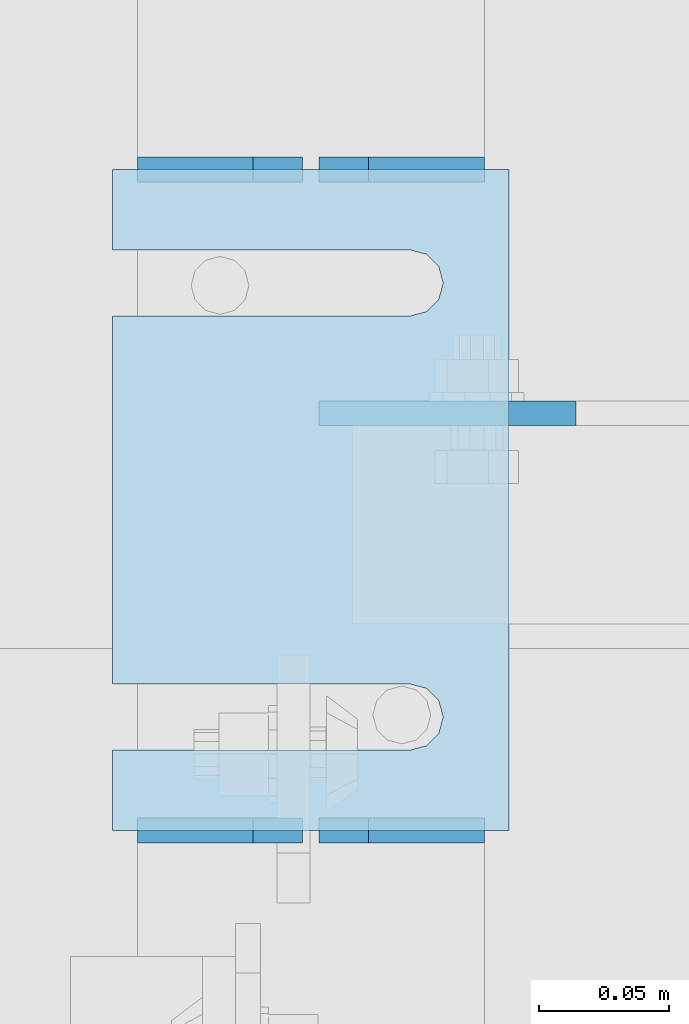
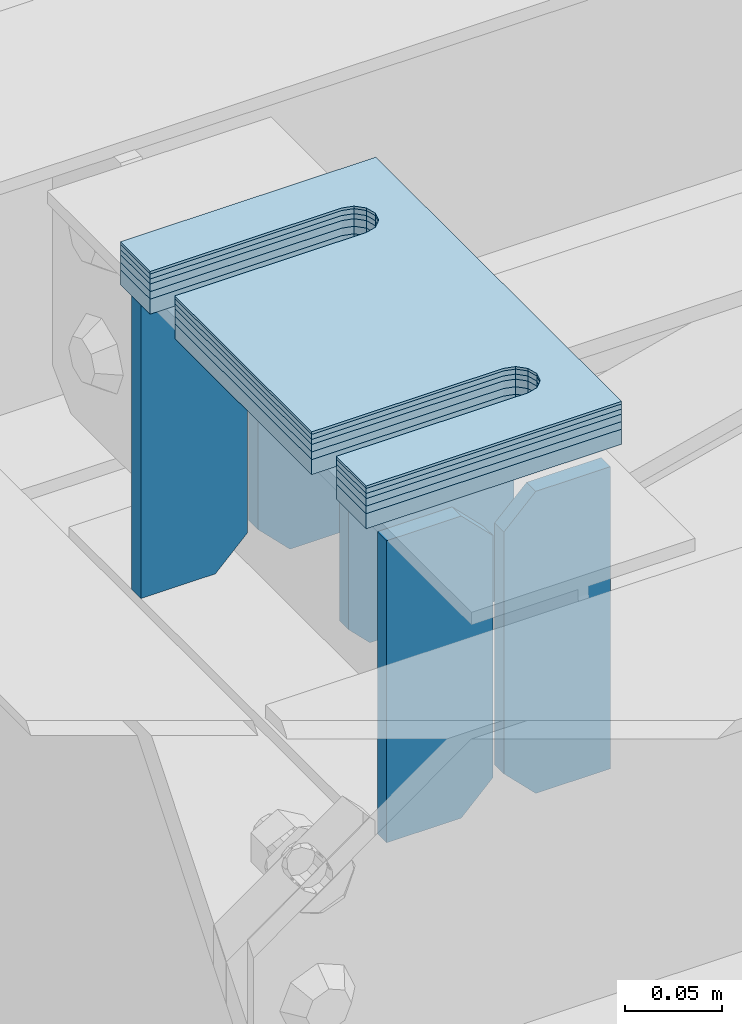
# One storey, part 1631 of 1876: 11 plates, 7 elements without a shape of their own.
"""IFC2X3 building model written with IfcOpenShell, lengths in millimetres."""

from ifc_helpers import new_model, si_unit, frame, origin_with_axes, place, context, subcontext, project, spatial, faceted_brep, material, type_object, element, aggregate, save


model = new_model("IFC2X3")

# Units and contexts
model_context = context("Model", 3, precision=1e-05, world=origin_with_axes())
body_context = subcontext(model_context, "Body", "Model", "MODEL_VIEW")
ifc_project = project(units=[si_unit("LENGTHUNIT", "METRE", prefix="MILLI"), si_unit("AREAUNIT", "SQUARE_METRE"), si_unit("VOLUMEUNIT", "CUBIC_METRE"), si_unit("MASSUNIT", "GRAM", prefix="KILO"), si_unit("TIMEUNIT", "SECOND"), si_unit("PLANEANGLEUNIT", "RADIAN"), si_unit("SOLIDANGLEUNIT", "STERADIAN"), si_unit("THERMODYNAMICTEMPERATUREUNIT", "DEGREE_CELSIUS"), si_unit("LUMINOUSINTENSITYUNIT", "LUMEN")], contexts=[model_context])

# Site, building, storey
site_placement = place(None, origin_with_axes())
site = spatial("IfcSite", under=ifc_project, at=site_placement, CompositionType="ELEMENT")
building_placement = place(site_placement, origin_with_axes())
building = spatial("IfcBuilding", under=site, at=building_placement, Name="Undefined", CompositionType="ELEMENT")
storey_placement = place(building_placement, origin_with_axes())
storey = spatial("IfcBuildingStorey", under=building, at=storey_placement, Name="Undefined", CompositionType="ELEMENT", Elevation=0.0)

# Assembly, plates
assembly_1_placement = place(storey_placement, origin_with_axes())
assembly_1 = element("IfcElementAssembly", 1, at=assembly_1_placement, inside=storey, Name="BEAM", AssemblyPlace="NOTDEFINED", PredefinedType="RIGID_FRAME")
ifc_material = material(Name="STEEL/A36")
plate_type_1 = type_object("IfcPlateType", PredefinedType="NOTDEFINED")
plate_1_placement = place(assembly_1_placement, frame((3188.08048423619, 5588.01551299106, 17784.7625), z_axis=(0.0, 0.0, 1.0), x_axis=(-1.0, 0.0, 0.0)))
plate_1 = element("IfcPlate", 2, at=plate_1_placement, type_object=plate_type_1, material=ifc_material, Name="PLATE", context=body_context, shape_type="Brep", body=[
    faceted_brep([(0.0, -4.76249999999982, 0.0), (0.0, -4.76249999999982, 190.5), (0.0, 4.76249999999982, 190.5), (0.0, 4.76249999999982, 0.0), (44.4500007629395, -4.76249999999982, 190.5), (44.4500007629395, 4.76249999999982, 190.5), (63.5, -4.76249999999982, 171.450000762939), (63.5, 4.76249999999982, 171.450000762939), (63.5, -4.76249999999982, 19.0499992370605), (63.5, 4.76249999999982, 19.0499992370605), (44.4500007629395, -4.76249999999982, 0.0), (44.4500007629395, 4.76249999999982, 0.0)], [[[0, 1, 2, 3]], [[1, 4, 5, 2]], [[4, 6, 7, 5]], [[6, 8, 9, 7]], [[8, 10, 11, 9]], [[10, 0, 3, 11]], [[5, 7, 9, 11, 3, 2]], [[10, 8, 6, 4, 1, 0]]]),
])
plate_2_placement = place(assembly_1_placement, frame((3118.23048423619, 5588.01551299106, 17784.7625), z_axis=(0.0, 0.0, 1.0), x_axis=(-1.0, 0.0, 0.0)))
plate_2 = element("IfcPlate", 3, at=plate_2_placement, type_object=plate_type_1, material=ifc_material, Name="PLATE", context=body_context, shape_type="Brep", body=[
    faceted_brep([(0.0, -4.76249999999982, 19.0499992370605), (0.0, -4.76249999999982, 171.450000762939), (0.0, 4.76249999999982, 171.450000762939), (0.0, 4.76249999999982, 19.0499992370605), (19.0499992370605, -4.76249999999982, 190.5), (19.0499992370605, 4.76249999999982, 190.5), (63.5, -4.76249999999982, 190.5), (63.5, 4.76249999999982, 190.5), (63.5, -4.76249999999982, 0.0), (63.5, 4.76249999999982, 0.0), (19.0499992370605, -4.76249999999982, 0.0), (19.0499992370605, 4.76249999999982, 0.0)], [[[0, 1, 2, 3]], [[1, 4, 5, 2]], [[4, 6, 7, 5]], [[6, 8, 9, 7]], [[8, 10, 11, 9]], [[10, 0, 3, 11]], [[5, 7, 9, 11, 3, 2]], [[10, 8, 6, 4, 1, 0]]]),
])
plate_3_placement = place(assembly_1_placement, frame((3188.08048423619, 5842.01505094658, 17784.7625), z_axis=(0.0, 0.0, 1.0), x_axis=(-1.0, 0.0, 0.0)))
plate_3 = element("IfcPlate", 4, at=plate_3_placement, type_object=plate_type_1, material=ifc_material, Name="PLATE", context=body_context, shape_type="Brep", body=[
    faceted_brep([(0.0, -4.76249999999982, 0.0), (0.0, -4.76249999999982, 190.5), (0.0, 4.76249999999982, 190.5), (0.0, 4.76249999999982, 0.0), (44.4500007629395, -4.76249999999982, 190.5), (44.4500007629395, 4.76249999999982, 190.5), (63.5, -4.76249999999982, 171.450000762939), (63.5, 4.76249999999982, 171.450000762939), (63.5, -4.76249999999982, 19.0499992370605), (63.5, 4.76249999999982, 19.0499992370605), (44.4500007629395, -4.76249999999982, 0.0), (44.4500007629395, 4.76249999999982, 0.0)], [[[0, 1, 2, 3]], [[1, 4, 5, 2]], [[4, 6, 7, 5]], [[6, 8, 9, 7]], [[8, 10, 11, 9]], [[10, 0, 3, 11]], [[5, 7, 9, 11, 3, 2]], [[10, 8, 6, 4, 1, 0]]]),
])
plate_4_placement = place(assembly_1_placement, frame((3118.23048423619, 5842.01505094658, 17784.7625), z_axis=(0.0, 0.0, 1.0), x_axis=(-1.0, 0.0, 0.0)))
plate_4 = element("IfcPlate", 5, at=plate_4_placement, type_object=plate_type_1, material=ifc_material, Name="PLATE", context=body_context, shape_type="Brep", body=[
    faceted_brep([(0.0, -4.76249999999982, 19.0499992370605), (0.0, -4.76249999999982, 171.450000762939), (0.0, 4.76249999999982, 171.450000762939), (0.0, 4.76249999999982, 19.0499992370605), (19.0499992370605, -4.76249999999982, 190.5), (19.0499992370605, 4.76249999999982, 190.5), (63.5, -4.76249999999982, 190.5), (63.5, 4.76249999999982, 190.5), (63.5, -4.76249999999982, 0.0), (63.5, 4.76249999999982, 0.0), (19.0499992370605, -4.76249999999982, 0.0), (19.0499992370605, 4.76249999999982, 0.0)], [[[0, 1, 2, 3]], [[1, 4, 5, 2]], [[4, 6, 7, 5]], [[6, 8, 9, 7]], [[8, 10, 11, 9]], [[10, 0, 3, 11]], [[5, 7, 9, 11, 3, 2]], [[10, 8, 6, 4, 1, 0]]]),
])
plate_type_2 = type_object("IfcPlateType", PredefinedType="NOTDEFINED")
plate_5_placement = place(assembly_1_placement, frame((3223.25213082928, 5748.35276155761, 17784.7625), z_axis=(-1.0, 0.0, 0.0), x_axis=(0.0, 0.0, 1.0)))
plate_5 = element("IfcPlate", 6, at=plate_5_placement, type_object=plate_type_2, material=ifc_material, Name="PLATE", context=body_context, shape_type="Brep", body=[
    faceted_brep([(0.0, -4.76249999999982, 0.0), (0.0, -4.76249999999163, 85.9716234207167), (0.0, 4.762500000008, 85.9716234207158), (0.0, 4.76249999999982, 0.0), (12.6999998092651, -4.76249999999072, 98.6716210911795), (12.6999998092651, 4.76250000000891, 98.6716210911786), (90.6052093505859, -4.76249999999072, 98.6716079711928), (90.6052093505859, 4.76250000000982, 98.6716079711914), (90.6052093505859, -4.76249999999891, 1.81898940354586e-12), (90.6052093505859, 4.76250000000073, 4.54747350886464e-13)], [[[0, 1, 2, 3]], [[1, 4, 5, 2]], [[4, 6, 7, 5]], [[6, 8, 9, 7]], [[8, 0, 3, 9]], [[5, 7, 9, 3, 2]], [[8, 6, 4, 1, 0]]]),
])
aggregate(assembly_1, [plate_1, plate_2, plate_3, plate_4, plate_5])

# Assembly, plate
assembly_2_placement = place(storey_placement, origin_with_axes())
assembly_2 = element("IfcElementAssembly", 7, at=assembly_2_placement, inside=storey, Name="SHIM PLATE", AssemblyPlace="NOTDEFINED", PredefinedType="RIGID_FRAME")
plate_type_3 = type_object("IfcPlateType", PredefinedType="NOTDEFINED")
plate_6_placement = place(assembly_2_placement, frame((3197.61613617069, 5588.01549354666, 18009.3925), z_axis=(-1.0, 0.0, 0.0), x_axis=(0.0, 1.0, 0.0)))
plate_6 = element("IfcPlate", 8, at=plate_6_placement, type_object=plate_type_3, material=ifc_material, Name="SHIM PLATE", context=body_context, shape_type="Brep", body=[
    faceted_brep([(30.8791924037423, -0.793499999999767, 152.398895263674), (30.8814140421409, -0.793499999999767, 38.0994505407325), (30.8814140421409, 0.793499999999767, 38.0994505407325), (30.8791924037423, 0.793499999999767, 152.398895263674), (32.5828868936751, -0.793499999999767, 31.7494480341243), (32.5828868936751, 0.793499999999767, 31.7494480341243), (37.2314075583954, -0.793499999999767, 27.1009216732054), (37.2314075583954, 0.793499999999767, 27.1009216732054), (43.5814079800521, -0.793499999999767, 25.3994410405157), (43.5814079800521, 0.793499999999767, 25.3994410405157), (49.9314097200559, -0.793499999999767, 27.1009167530574), (49.9314097200559, 0.793499999999767, 27.1009167530574), (54.5799339865616, -0.793499999999767, 31.7494395121785), (54.5799339865616, 0.793499999999767, 31.7494395121785), (56.2814117582284, -0.793499999999767, 38.0994407004391), (56.2814117582284, 0.793499999999767, 38.0994407004391), (56.2791901197206, -0.793499999999767, 152.398894414155), (56.2791901197206, 0.793499999999767, 152.398895263676), (9.09494701772928e-13, -0.793499999999767, 0.0), (1.98268335225293e-05, -0.793499999999767, 152.398895263672), (1.98268335225293e-05, 0.793499999999767, 152.398895263672), (9.09494701772928e-13, 0.793499999999767, 0.0), (253.999542236328, -0.793499999999767, 6.16182660451159e-11), (253.999542236328, 0.793499999999767, 6.16182660451159e-11), (253.999557495107, -0.793499999999767, 152.398895263688), (253.999557495107, 0.793499999999767, 152.398895263688), (223.116882380463, 0.793499999999767, 152.398895263686), (223.116882380463, -0.793499999999767, 152.398895415181), (223.119104018971, 0.793499999999767, 38.0994417014649), (223.119104018971, -0.793499999999767, 38.0994417014649), (221.417626247304, 0.793499999999767, 31.7494405132047), (221.417626247304, -0.793499999999767, 31.7494405132047), (216.769101980798, 0.793499999999767, 27.1009177540836), (216.769101980798, -0.793499999999767, 27.1009177540836), (210.419100240794, 0.793499999999767, 25.399442041542), (210.419100240794, -0.793499999999767, 25.399442041542), (204.069099819138, 0.793499999999767, 27.1009226742317), (204.069099819138, -0.793499999999767, 27.1009226742317), (199.420579154417, 0.793499999999767, 31.7494490351505), (199.420579154417, -0.793499999999767, 31.7494490351505), (197.719106302883, 0.793499999999767, 38.0994515417583), (197.719106302883, -0.793499999999767, 38.0994515417583), (197.716884664484, -0.793499999999767, 152.398895263684), (197.716884664484, 0.793499999999767, 152.398895263684)], [[[0, 1, 2, 3]], [[4, 5, 2, 1]], [[6, 7, 5, 4]], [[8, 9, 7, 6]], [[10, 11, 9, 8]], [[12, 13, 11, 10]], [[14, 15, 13, 12]], [[16, 17, 15, 14]], [[18, 19, 20, 21]], [[22, 18, 21, 23]], [[24, 22, 23, 25]], [[24, 25, 26, 27]], [[27, 26, 28, 29]], [[29, 28, 30, 31]], [[31, 30, 32, 33]], [[33, 32, 34, 35]], [[35, 34, 36, 37]], [[37, 36, 38, 39]], [[39, 38, 40, 41]], [[42, 41, 40, 43]], [[12, 10, 8, 6, 4, 1, 0, 19, 18, 22, 24, 27, 29, 31, 33, 35, 37, 39, 41, 42, 16, 14]], [[20, 19, 0, 3]], [[43, 40, 38, 36, 34, 32, 30, 28, 26, 25, 23, 21, 20, 3, 2, 5, 7, 9, 11, 13, 15, 17]], [[42, 43, 17, 16]]]),
])
aggregate(assembly_2, [plate_6])

assembly_3_placement = place(storey_placement, origin_with_axes())
assembly_3 = element("IfcElementAssembly", 9, at=assembly_3_placement, inside=storey, Name="SHIM PLATE", AssemblyPlace="NOTDEFINED", PredefinedType="RIGID_FRAME")
plate_type_4 = type_object("IfcPlateType", PredefinedType="NOTDEFINED")
plate_7_placement = place(assembly_3_placement, frame((3197.61613617092, 5588.01549354666, 18007.0115), z_axis=(-1.0, 0.0, 0.0), x_axis=(0.0, 1.0, 0.0)))
plate_7 = element("IfcPlate", 10, at=plate_7_placement, type_object=plate_type_4, material=ifc_material, Name="SHIM PLATE", context=body_context, shape_type="Brep", body=[
    faceted_brep([(30.8791924037423, -1.58750000000146, 152.398895263674), (30.8814140421409, -1.58750000000146, 38.0994505407325), (30.8814140421409, 1.58750000000146, 38.0994505407325), (30.8791924037423, 1.58750000000146, 152.398895263674), (32.5828868936751, -1.58750000000146, 31.7494480341243), (32.5828868936751, 1.58750000000146, 31.7494480341243), (37.2314075583954, -1.58750000000146, 27.1009216732054), (37.2314075583954, 1.58750000000146, 27.1009216732054), (43.5814079800521, -1.58750000000146, 25.3994410405157), (43.5814079800521, 1.58750000000146, 25.3994410405157), (49.9314097200559, -1.58750000000146, 27.1009167530574), (49.9314097200559, 1.58750000000146, 27.1009167530574), (54.5799339865616, -1.58750000000146, 31.7494395121785), (54.5799339865616, 1.58750000000146, 31.7494395121785), (56.2814117582284, -1.58750000000146, 38.0994407004391), (56.2814117582284, 1.58750000000146, 38.0994407004391), (56.2791901197206, -1.58750000000146, 152.398894414155), (56.2791901197206, 1.58750000000146, 152.398895263676), (9.09494701772928e-13, -1.58750000000146, 4.54747350886464e-13), (1.98264133359771e-05, -1.58750000000146, 152.398895263672), (1.98264133359771e-05, 1.58750000000146, 152.398895263672), (9.09494701772928e-13, 1.58750000000146, 4.54747350886464e-13), (253.999542236328, -1.58750000000146, 6.16182660451159e-11), (253.999542236328, 1.58750000000146, 6.16182660451159e-11), (253.999557495107, -1.58750000000146, 152.398895263688), (253.999557495107, 1.58750000000146, 152.398895263688), (223.116882380463, 1.58750000000146, 152.398895263686), (223.116882380463, -1.58750000000146, 152.398895415181), (223.119104018971, 1.58750000000146, 38.0994417014649), (223.119104018971, -1.58750000000146, 38.0994417014649), (221.417626247304, 1.58750000000146, 31.7494405132047), (221.417626247304, -1.58750000000146, 31.7494405132047), (216.769101980798, 1.58750000000146, 27.1009177540836), (216.769101980798, -1.58750000000146, 27.1009177540836), (210.419100240794, 1.58750000000146, 25.399442041542), (210.419100240794, -1.58750000000146, 25.399442041542), (204.069099819138, 1.58750000000146, 27.1009226742317), (204.069099819138, -1.58750000000146, 27.1009226742317), (199.420579154417, 1.58750000000146, 31.7494490351505), (199.420579154417, -1.58750000000146, 31.7494490351505), (197.719106302883, 1.58750000000146, 38.0994515417583), (197.719106302883, -1.58750000000146, 38.0994515417583), (197.716884664484, -1.58750000000146, 152.398895263684), (197.716884664484, 1.58750000000146, 152.398895263684)], [[[0, 1, 2, 3]], [[4, 5, 2, 1]], [[6, 7, 5, 4]], [[8, 9, 7, 6]], [[10, 11, 9, 8]], [[12, 13, 11, 10]], [[14, 15, 13, 12]], [[16, 17, 15, 14]], [[18, 19, 20, 21]], [[22, 18, 21, 23]], [[24, 22, 23, 25]], [[24, 25, 26, 27]], [[27, 26, 28, 29]], [[29, 28, 30, 31]], [[31, 30, 32, 33]], [[33, 32, 34, 35]], [[35, 34, 36, 37]], [[37, 36, 38, 39]], [[39, 38, 40, 41]], [[42, 41, 40, 43]], [[12, 10, 8, 6, 4, 1, 0, 19, 18, 22, 24, 27, 29, 31, 33, 35, 37, 39, 41, 42, 16, 14]], [[20, 19, 0, 3]], [[43, 40, 38, 36, 34, 32, 30, 28, 26, 25, 23, 21, 20, 3, 2, 5, 7, 9, 11, 13, 15, 17]], [[42, 43, 17, 16]]]),
])
aggregate(assembly_3, [plate_7])

assembly_4_placement = place(storey_placement, origin_with_axes())
assembly_4 = element("IfcElementAssembly", 11, at=assembly_4_placement, inside=storey, Name="SHIM PLATE", AssemblyPlace="NOTDEFINED", PredefinedType="RIGID_FRAME")
plate_8_placement = place(assembly_4_placement, frame((3197.61613617115, 5588.01549354666, 18003.8365), z_axis=(-1.0, 0.0, 0.0), x_axis=(0.0, 1.0, 0.0)))
plate_8 = element("IfcPlate", 12, at=plate_8_placement, type_object=plate_type_4, material=ifc_material, Name="SHIM PLATE", context=body_context, shape_type="Brep", body=[
    faceted_brep([(30.8791924037423, -1.58750000000146, 152.398895263674), (30.8814140421409, -1.58750000000146, 38.0994505407325), (30.8814140421409, 1.58750000000146, 38.0994505407325), (30.8791924037423, 1.58750000000146, 152.398895263674), (32.5828868936751, -1.58750000000146, 31.7494480341243), (32.5828868936751, 1.58750000000146, 31.7494480341243), (37.2314075583954, -1.58750000000146, 27.1009216732054), (37.2314075583954, 1.58750000000146, 27.1009216732054), (43.5814079800521, -1.58750000000146, 25.3994410405157), (43.5814079800521, 1.58750000000146, 25.3994410405157), (49.9314097200559, -1.58750000000146, 27.1009167530574), (49.9314097200559, 1.58750000000146, 27.1009167530574), (54.5799339865616, -1.58750000000146, 31.7494395121785), (54.5799339865616, 1.58750000000146, 31.7494395121785), (56.2814117582284, -1.58750000000146, 38.0994407004391), (56.2814117582284, 1.58750000000146, 38.0994407004391), (56.2791901197206, -1.58750000000146, 152.398894414155), (56.2791901197206, 1.58750000000146, 152.398895263676), (9.09494701772928e-13, -1.58750000000146, 4.54747350886464e-13), (1.98264133359771e-05, -1.58750000000146, 152.398895263672), (1.98264133359771e-05, 1.58750000000146, 152.398895263672), (9.09494701772928e-13, 1.58750000000146, 4.54747350886464e-13), (253.999542236328, -1.58750000000146, 6.16182660451159e-11), (253.999542236328, 1.58750000000146, 6.16182660451159e-11), (253.999557495107, -1.58750000000146, 152.398895263688), (253.999557495107, 1.58750000000146, 152.398895263688), (223.116882380463, 1.58750000000146, 152.398895263686), (223.116882380463, -1.58750000000146, 152.398895415181), (223.119104018971, 1.58750000000146, 38.0994417014649), (223.119104018971, -1.58750000000146, 38.0994417014649), (221.417626247304, 1.58750000000146, 31.7494405132047), (221.417626247304, -1.58750000000146, 31.7494405132047), (216.769101980798, 1.58750000000146, 27.1009177540836), (216.769101980798, -1.58750000000146, 27.1009177540836), (210.419100240794, 1.58750000000146, 25.399442041542), (210.419100240794, -1.58750000000146, 25.399442041542), (204.069099819138, 1.58750000000146, 27.1009226742317), (204.069099819138, -1.58750000000146, 27.1009226742317), (199.420579154417, 1.58750000000146, 31.7494490351505), (199.420579154417, -1.58750000000146, 31.7494490351505), (197.719106302883, 1.58750000000146, 38.0994515417583), (197.719106302883, -1.58750000000146, 38.0994515417583), (197.716884664484, -1.58750000000146, 152.398895263684), (197.716884664484, 1.58750000000146, 152.398895263684)], [[[0, 1, 2, 3]], [[4, 5, 2, 1]], [[6, 7, 5, 4]], [[8, 9, 7, 6]], [[10, 11, 9, 8]], [[12, 13, 11, 10]], [[14, 15, 13, 12]], [[16, 17, 15, 14]], [[18, 19, 20, 21]], [[22, 18, 21, 23]], [[24, 22, 23, 25]], [[24, 25, 26, 27]], [[27, 26, 28, 29]], [[29, 28, 30, 31]], [[31, 30, 32, 33]], [[33, 32, 34, 35]], [[35, 34, 36, 37]], [[37, 36, 38, 39]], [[39, 38, 40, 41]], [[42, 41, 40, 43]], [[12, 10, 8, 6, 4, 1, 0, 19, 18, 22, 24, 27, 29, 31, 33, 35, 37, 39, 41, 42, 16, 14]], [[20, 19, 0, 3]], [[43, 40, 38, 36, 34, 32, 30, 28, 26, 25, 23, 21, 20, 3, 2, 5, 7, 9, 11, 13, 15, 17]], [[42, 43, 17, 16]]]),
])
aggregate(assembly_4, [plate_8])

assembly_5_placement = place(storey_placement, origin_with_axes())
assembly_5 = element("IfcElementAssembly", 13, at=assembly_5_placement, inside=storey, Name="SHIM PLATE", AssemblyPlace="NOTDEFINED", PredefinedType="RIGID_FRAME")
plate_type_5 = type_object("IfcPlateType", PredefinedType="NOTDEFINED")
plate_9_placement = place(assembly_5_placement, frame((3197.61613617138, 5588.01549354666, 17999.868), z_axis=(-1.0, 0.0, 0.0), x_axis=(0.0, 1.0, 0.0)))
plate_9 = element("IfcPlate", 14, at=plate_9_placement, type_object=plate_type_5, material=ifc_material, Name="SHIM PLATE", context=body_context, shape_type="Brep", body=[
    faceted_brep([(30.8791924037423, -2.38100000000122, 152.398895263674), (30.8814140421409, -2.38100000000122, 38.0994505407325), (30.8814140421409, 2.38100000000122, 38.0994505407325), (30.8791924037423, 2.38100000000122, 152.398895263674), (32.5828868936751, -2.38100000000122, 31.7494480341243), (32.5828868936751, 2.38100000000122, 31.7494480341243), (37.2314075583954, -2.38100000000122, 27.1009216732054), (37.2314075583954, 2.38100000000122, 27.1009216732054), (43.5814079800521, -2.38100000000122, 25.3994410405157), (43.5814079800521, 2.38100000000122, 25.3994410405157), (49.9314097200559, -2.38100000000122, 27.1009167530574), (49.9314097200559, 2.38100000000122, 27.1009167530574), (54.5799339865616, -2.38100000000122, 31.7494395121785), (54.5799339865616, 2.38100000000122, 31.7494395121785), (56.2814117582284, -2.38100000000122, 38.0994407004391), (56.2814117582284, 2.38100000000122, 38.0994407004391), (56.2791901197206, -2.38100000000122, 152.398894414155), (56.2791901197206, 2.38100000000122, 152.398895263676), (0.0, -2.38100000000122, 4.54747350886464e-13), (1.98259931494249e-05, -2.38100000000122, 152.398895263672), (1.98259931494249e-05, 2.38100000000122, 152.398895263672), (0.0, 2.38100000000122, 4.54747350886464e-13), (253.999542236328, -2.38100000000122, 6.16182660451159e-11), (253.999542236328, 2.38100000000122, 6.16182660451159e-11), (253.999557495107, -2.38100000000122, 152.398895263688), (253.999557495107, 2.38100000000122, 152.398895263688), (223.116882380463, 2.38100000000122, 152.398895263686), (223.116882380463, -2.38100000000122, 152.398895415181), (223.119104018971, 2.38100000000122, 38.0994417014649), (223.119104018971, -2.38100000000122, 38.0994417014649), (221.417626247304, 2.38100000000122, 31.7494405132047), (221.417626247304, -2.38100000000122, 31.7494405132047), (216.769101980798, 2.38100000000122, 27.1009177540836), (216.769101980798, -2.38100000000122, 27.1009177540836), (210.419100240794, 2.38100000000122, 25.399442041542), (210.419100240794, -2.38100000000122, 25.399442041542), (204.069099819138, 2.38100000000122, 27.1009226742317), (204.069099819138, -2.38100000000122, 27.1009226742317), (199.420579154417, 2.38100000000122, 31.7494490351505), (199.420579154417, -2.38100000000122, 31.7494490351505), (197.719106302883, 2.38100000000122, 38.0994515417583), (197.719106302883, -2.38100000000122, 38.0994515417583), (197.716884664484, -2.38100000000122, 152.398895263684), (197.716884664484, 2.38100000000122, 152.398895263684)], [[[0, 1, 2, 3]], [[4, 5, 2, 1]], [[6, 7, 5, 4]], [[8, 9, 7, 6]], [[10, 11, 9, 8]], [[12, 13, 11, 10]], [[14, 15, 13, 12]], [[16, 17, 15, 14]], [[18, 19, 20, 21]], [[22, 18, 21, 23]], [[24, 22, 23, 25]], [[24, 25, 26, 27]], [[27, 26, 28, 29]], [[29, 28, 30, 31]], [[31, 30, 32, 33]], [[33, 32, 34, 35]], [[35, 34, 36, 37]], [[37, 36, 38, 39]], [[39, 38, 40, 41]], [[42, 41, 40, 43]], [[12, 10, 8, 6, 4, 1, 0, 19, 18, 22, 24, 27, 29, 31, 33, 35, 37, 39, 41, 42, 16, 14]], [[20, 19, 0, 3]], [[43, 40, 38, 36, 34, 32, 30, 28, 26, 25, 23, 21, 20, 3, 2, 5, 7, 9, 11, 13, 15, 17]], [[42, 43, 17, 16]]]),
])
aggregate(assembly_5, [plate_9])

assembly_6_placement = place(storey_placement, origin_with_axes())
assembly_6 = element("IfcElementAssembly", 15, at=assembly_6_placement, inside=storey, Name="SHIM PLATE", AssemblyPlace="NOTDEFINED", PredefinedType="RIGID_FRAME")
plate_10_placement = place(assembly_6_placement, frame((3197.61613617161, 5588.01549354666, 17995.106), z_axis=(-1.0, 0.0, 0.0), x_axis=(0.0, 1.0, 0.0)))
plate_10 = element("IfcPlate", 16, at=plate_10_placement, type_object=plate_type_5, material=ifc_material, Name="SHIM PLATE", context=body_context, shape_type="Brep", body=[
    faceted_brep([(30.8791924037423, -2.38100000000122, 152.398895263674), (30.8814140421409, -2.38100000000122, 38.0994505407325), (30.8814140421409, 2.38100000000122, 38.0994505407325), (30.8791924037423, 2.38100000000122, 152.398895263674), (32.5828868936751, -2.38100000000122, 31.7494480341243), (32.5828868936751, 2.38100000000122, 31.7494480341243), (37.2314075583954, -2.38100000000122, 27.1009216732054), (37.2314075583954, 2.38100000000122, 27.1009216732054), (43.5814079800521, -2.38100000000122, 25.3994410405157), (43.5814079800521, 2.38100000000122, 25.3994410405157), (49.9314097200559, -2.38100000000122, 27.1009167530574), (49.9314097200559, 2.38100000000122, 27.1009167530574), (54.5799339865616, -2.38100000000122, 31.7494395121785), (54.5799339865616, 2.38100000000122, 31.7494395121785), (56.2814117582284, -2.38100000000122, 38.0994407004391), (56.2814117582284, 2.38100000000122, 38.0994407004391), (56.2791901197206, -2.38100000000122, 152.398894414155), (56.2791901197206, 2.38100000000122, 152.398895263676), (0.0, -2.38100000000122, 4.54747350886464e-13), (1.98259931494249e-05, -2.38100000000122, 152.398895263672), (1.98259931494249e-05, 2.38100000000122, 152.398895263672), (0.0, 2.38100000000122, 4.54747350886464e-13), (253.999542236328, -2.38100000000122, 6.16182660451159e-11), (253.999542236328, 2.38100000000122, 6.16182660451159e-11), (253.999557495107, -2.38100000000122, 152.398895263688), (253.999557495107, 2.38100000000122, 152.398895263688), (223.116882380463, 2.38100000000122, 152.398895263686), (223.116882380463, -2.38100000000122, 152.398895415181), (223.119104018971, 2.38100000000122, 38.0994417014649), (223.119104018971, -2.38100000000122, 38.0994417014649), (221.417626247304, 2.38100000000122, 31.7494405132047), (221.417626247304, -2.38100000000122, 31.7494405132047), (216.769101980798, 2.38100000000122, 27.1009177540836), (216.769101980798, -2.38100000000122, 27.1009177540836), (210.419100240794, 2.38100000000122, 25.399442041542), (210.419100240794, -2.38100000000122, 25.399442041542), (204.069099819138, 2.38100000000122, 27.1009226742317), (204.069099819138, -2.38100000000122, 27.1009226742317), (199.420579154417, 2.38100000000122, 31.7494490351505), (199.420579154417, -2.38100000000122, 31.7494490351505), (197.719106302883, 2.38100000000122, 38.0994515417583), (197.719106302883, -2.38100000000122, 38.0994515417583), (197.716884664484, -2.38100000000122, 152.398895263684), (197.716884664484, 2.38100000000122, 152.398895263684)], [[[0, 1, 2, 3]], [[4, 5, 2, 1]], [[6, 7, 5, 4]], [[8, 9, 7, 6]], [[10, 11, 9, 8]], [[12, 13, 11, 10]], [[14, 15, 13, 12]], [[16, 17, 15, 14]], [[18, 19, 20, 21]], [[22, 18, 21, 23]], [[24, 22, 23, 25]], [[24, 25, 26, 27]], [[27, 26, 28, 29]], [[29, 28, 30, 31]], [[31, 30, 32, 33]], [[33, 32, 34, 35]], [[35, 34, 36, 37]], [[37, 36, 38, 39]], [[39, 38, 40, 41]], [[42, 41, 40, 43]], [[12, 10, 8, 6, 4, 1, 0, 19, 18, 22, 24, 27, 29, 31, 33, 35, 37, 39, 41, 42, 16, 14]], [[20, 19, 0, 3]], [[43, 40, 38, 36, 34, 32, 30, 28, 26, 25, 23, 21, 20, 3, 2, 5, 7, 9, 11, 13, 15, 17]], [[42, 43, 17, 16]]]),
])
aggregate(assembly_6, [plate_10])

assembly_7_placement = place(storey_placement, origin_with_axes())
assembly_7 = element("IfcElementAssembly", 17, at=assembly_7_placement, inside=storey, Name="SHIM PLATE", AssemblyPlace="NOTDEFINED", PredefinedType="RIGID_FRAME")
plate_type_6 = type_object("IfcPlateType", PredefinedType="NOTDEFINED")
plate_11_placement = place(assembly_7_placement, frame((3197.61613617184, 5588.01549354666, 17987.9625), z_axis=(-1.0, 0.0, 0.0), x_axis=(0.0, 1.0, 0.0)))
plate_11 = element("IfcPlate", 18, at=plate_11_placement, type_object=plate_type_6, material=ifc_material, Name="SHIM PLATE", context=body_context, shape_type="Brep", body=[
    faceted_brep([(30.8791924037423, -4.76250000000073, 152.398895263674), (30.8814140421409, -4.76250000000073, 38.0994505407325), (30.8814140421409, 4.76250000000073, 38.0994505407325), (30.8791924037423, 4.76250000000073, 152.398895263674), (32.5828868936751, -4.76250000000073, 31.7494480341243), (32.5828868936751, 4.76250000000073, 31.7494480341243), (37.2314075583954, -4.76250000000073, 27.1009216732054), (37.2314075583954, 4.76250000000073, 27.1009216732054), (43.5814079800521, -4.76250000000073, 25.3994410405157), (43.5814079800521, 4.76250000000073, 25.3994410405157), (49.9314097200559, -4.76250000000073, 27.1009167530574), (49.9314097200559, 4.76250000000073, 27.1009167530574), (54.5799339865616, -4.76250000000073, 31.7494395121785), (54.5799339865616, 4.76250000000073, 31.7494395121785), (56.2814117582284, -4.76250000000073, 38.0994407004391), (56.2814117582284, 4.76250000000073, 38.0994407004391), (56.2791901197206, -4.76250000000073, 152.398894414155), (56.2791901197206, 4.76250000000073, 152.398895263676), (0.0, -4.76249999999982, 0.0), (1.98255729628727e-05, -4.76250000000073, 152.398895263672), (1.98255729628727e-05, 4.76250000000073, 152.398895263672), (0.0, 4.76249999999982, 0.0), (253.999542236328, -4.76250000000073, 6.16182660451159e-11), (253.999542236328, 4.76250000000073, 6.16182660451159e-11), (253.999557495107, -4.76250000000073, 152.398895263688), (253.999557495107, 4.76250000000073, 152.398895263688), (223.116882380463, 4.76250000000073, 152.398895263686), (223.116882380463, -4.76250000000073, 152.398895415181), (223.119104018971, 4.76250000000073, 38.0994417014649), (223.119104018971, -4.76250000000073, 38.0994417014649), (221.417626247304, 4.76250000000073, 31.7494405132047), (221.417626247304, -4.76250000000073, 31.7494405132047), (216.769101980798, 4.76250000000073, 27.1009177540836), (216.769101980798, -4.76250000000073, 27.1009177540836), (210.419100240794, 4.76250000000073, 25.399442041542), (210.419100240794, -4.76250000000073, 25.399442041542), (204.069099819138, 4.76250000000073, 27.1009226742317), (204.069099819138, -4.76250000000073, 27.1009226742317), (199.420579154417, 4.76250000000073, 31.7494490351505), (199.420579154417, -4.76250000000073, 31.7494490351505), (197.719106302883, 4.76250000000073, 38.0994515417583), (197.719106302883, -4.76250000000073, 38.0994515417583), (197.716884664484, -4.76250000000073, 152.398895263684), (197.716884664484, 4.76250000000073, 152.398895263684)], [[[0, 1, 2, 3]], [[4, 5, 2, 1]], [[6, 7, 5, 4]], [[8, 9, 7, 6]], [[10, 11, 9, 8]], [[12, 13, 11, 10]], [[14, 15, 13, 12]], [[16, 17, 15, 14]], [[18, 19, 20, 21]], [[22, 18, 21, 23]], [[24, 22, 23, 25]], [[24, 25, 26, 27]], [[27, 26, 28, 29]], [[29, 28, 30, 31]], [[31, 30, 32, 33]], [[33, 32, 34, 35]], [[35, 34, 36, 37]], [[37, 36, 38, 39]], [[39, 38, 40, 41]], [[42, 41, 40, 43]], [[12, 10, 8, 6, 4, 1, 0, 19, 18, 22, 24, 27, 29, 31, 33, 35, 37, 39, 41, 42, 16, 14]], [[20, 19, 0, 3]], [[43, 40, 38, 36, 34, 32, 30, 28, 26, 25, 23, 21, 20, 3, 2, 5, 7, 9, 11, 13, 15, 17]], [[42, 43, 17, 16]]]),
])
aggregate(assembly_7, [plate_11])

save(model, "model.ifc")
